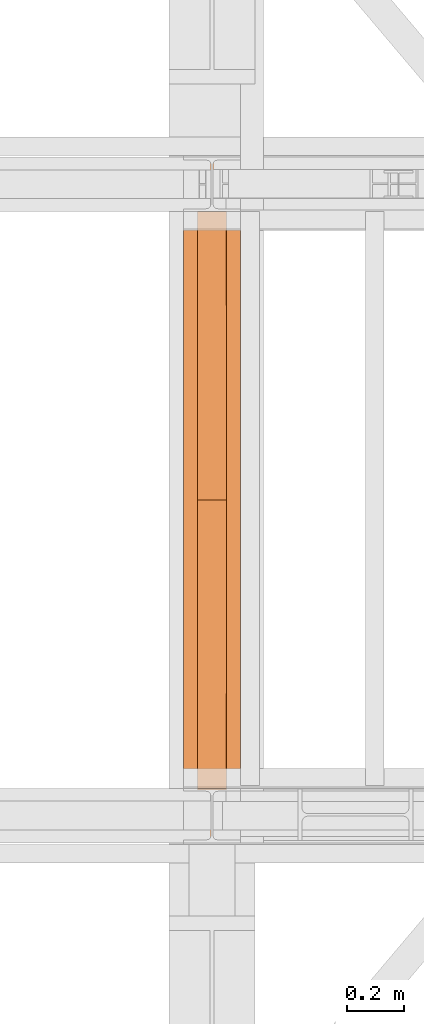
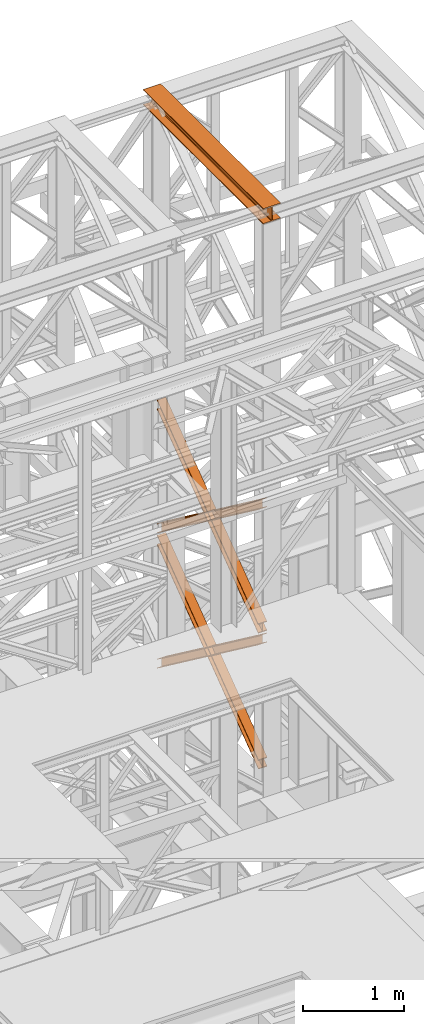
# One storey, part 167 of 208: 5 proxies.
"""IFC2X3 building model written with IfcOpenShell, lengths in millimetres."""

from ifc_helpers import new_model, entity, si_unit, converted_unit, frame, origin, origin_with_axes, place, context, subcontext, project, spatial, faceted_brep, element, save


model = new_model("IFC2X3")

# Units and contexts
model_context = context("Model", 3, precision=1e-05, world=origin())
plan_context = context("Plan", 3, precision=1e-05, world=origin())
body_context = subcontext(model_context, "Body", "Model", "MODEL_VIEW")
ifc_project = project(units=[si_unit("LENGTHUNIT", "METRE", prefix="MILLI"), converted_unit("PLANEANGLEUNIT", "DEGREE", entity("IfcPlaneAngleMeasure", 0.0174532925199433), si_unit("PLANEANGLEUNIT", "RADIAN"), dimensions=[0, 0, 0, 0, 0, 0, 0]), si_unit("AREAUNIT", "SQUARE_METRE"), si_unit("VOLUMEUNIT", "CUBIC_METRE")], contexts=[model_context, plan_context])

# Building, storey
building_placement = place(None, origin())
building = spatial("IfcBuilding", under=ifc_project, at=building_placement, CompositionType="COMPLEX")
storey_placement = place(building_placement, origin_with_axes())
storey = spatial("IfcBuildingStorey", under=building, at=storey_placement, Name="Geschoss", CompositionType="ELEMENT")

# Proxies
proxy_1_placement = place(storey_placement, frame((6493.25496703855, -16057.57439657638, 12249.99005869381), z_axis=(0.0, 0.0, 1.0), x_axis=(1.0, 0.0, 0.0)))
element("IfcBuildingElementProxy", 1, at=proxy_1_placement, inside=storey, context=body_context, shape_type="Brep", body=[
    faceted_brep([(0.01000000000021828, 2390.010012516977, 0.01000000000021828), (200.0100029802325, 2390.010012516977, 0.01000000000021828), (200.0100029802325, 2390.010012516977, 10.00999791383765), (121.2600035762789, 2390.010012516977, 10.01000536441825), (111.9441915473344, 2390.010012516977, 11.87455041170142), (105.1245498640838, 2390.010012516977, 18.69419349193595), (103.2600015571716, 2390.010012516977, 28.01000458955787), (103.2600015571716, 2390.010012516977, 162.0100153779986), (105.1245498640838, 2390.010012516977, 171.3258264756205), (111.9441915473344, 2390.010012516977, 178.145469555855), (121.2600035762789, 2390.010012516977, 180.0100146031382), (200.0100029802325, 2390.010012516977, 180.0100146031382), (200.0100029802325, 2390.010012516977, 190.0100125169756), (0.01000000000021828, 2390.010012516977, 190.0100125169756), (0.01000000000021828, 2390.010012516977, 180.0100146031382), (78.75999940395377, 2390.010012516977, 180.0100146031382), (88.07581143289826, 2390.010012516977, 178.145469555855), (94.89545311614893, 2390.010012516977, 171.3258264756205), (96.76000142306111, 2390.010012516977, 162.0100153779986), (96.76000142306111, 2390.010012516977, 28.01000458955787), (94.89545311614893, 2390.010012516977, 18.69419349193595), (88.07581143289826, 2390.010012516977, 11.87455041170142), (78.75999940395377, 2390.010012516977, 10.01000536441825), (0.01000000000021828, 2390.010012516977, 10.00999791383765), (200.0100029802325, 2390.010012516977, 0.01000000000021828), (0.01000000000021828, 2390.010012516977, 0.01000000000021828), (0.01000000000021828, 0.01000000000021828, 0.01000000000021828), (200.0100029802325, 0.01000000000021828, 0.01000000000021828), (200.0100029802325, 2390.010012516977, 10.00999791383765), (200.0100029802325, 2390.010012516977, 0.01000000000021828), (200.0100029802325, 0.01000000000021828, 0.01000000000021828), (200.0100029802325, 0.01000000000021828, 10.00999791383765), (121.2600035762789, 2390.010012516977, 10.01000536441825), (200.0100029802325, 2390.010012516977, 10.00999791383765), (200.0100029802325, 0.01000000000021828, 10.00999791383765), (121.2600035762789, 0.01000000000021828, 10.01000536441825), (111.9441915473344, 2390.010012516977, 11.87455041170142), (121.2600035762789, 2390.010012516977, 10.01000536441825), (121.2600035762789, 0.01000000000021828, 10.01000536441825), (111.9441915473344, 0.01000000000021828, 11.87455041170142), (105.1245498640838, 2390.010012516977, 18.69419349193595), (111.9441915473344, 2390.010012516977, 11.87455041170142), (111.9441915473344, 0.01000000000021828, 11.87455041170142), (105.1245498640838, 0.01000000000021828, 18.69419349193595), (103.2600015571716, 2390.010012516977, 28.01000458955787), (105.1245498640838, 2390.010012516977, 18.69419349193595), (105.1245498640838, 0.01000000000021828, 18.69419349193595), (103.2600015571716, 0.01000000000021828, 28.01000458955787), (103.2600015571716, 2390.010012516977, 162.0100153779986), (103.2600015571716, 2390.010012516977, 28.01000458955787), (103.2600015571716, 0.01000000000021828, 28.01000458955787), (103.2600015571716, 0.01000000000021828, 162.0100153779986), (105.1245498640838, 2390.010012516977, 171.3258264756205), (103.2600015571716, 2390.010012516977, 162.0100153779986), (103.2600015571716, 0.01000000000021828, 162.0100153779986), (105.1245498640838, 0.01000000000021828, 171.3258264756205), (111.9441915473344, 2390.010012516977, 178.145469555855), (105.1245498640838, 2390.010012516977, 171.3258264756205), (105.1245498640838, 0.01000000000021828, 171.3258264756205), (111.9441915473344, 0.01000000000021828, 178.145469555855), (121.2600035762789, 2390.010012516977, 180.0100146031382), (111.9441915473344, 2390.010012516977, 178.145469555855), (111.9441915473344, 0.01000000000021828, 178.145469555855), (121.2600035762789, 0.01000000000021828, 180.0100146031382), (200.0100029802325, 2390.010012516977, 180.0100146031382), (121.2600035762789, 2390.010012516977, 180.0100146031382), (121.2600035762789, 0.01000000000021828, 180.0100146031382), (200.0100029802325, 0.01000000000021828, 180.0100146031382), (200.0100029802325, 2390.010012516977, 190.0100125169756), (200.0100029802325, 2390.010012516977, 180.0100146031382), (200.0100029802325, 0.01000000000021828, 180.0100146031382), (200.0100029802325, 0.01000000000021828, 190.0100125169756), (0.01000000000021828, 2390.010012516977, 190.0100125169756), (200.0100029802325, 2390.010012516977, 190.0100125169756), (200.0100029802325, 0.01000000000021828, 190.0100125169756), (0.01000000000021828, 0.01000000000021828, 190.0100125169756), (0.01000000000021828, 2390.010012516977, 180.0100146031382), (0.01000000000021828, 2390.010012516977, 190.0100125169756), (0.01000000000021828, 0.01000000000021828, 190.0100125169756), (0.01000000000021828, 0.01000000000021828, 180.0100146031382), (78.75999940395377, 2390.010012516977, 180.0100146031382), (0.01000000000021828, 2390.010012516977, 180.0100146031382), (0.01000000000021828, 0.01000000000021828, 180.0100146031382), (78.75999940395377, 0.01000000000021828, 180.0100146031382), (88.07581143289826, 2390.010012516977, 178.145469555855), (78.75999940395377, 2390.010012516977, 180.0100146031382), (78.75999940395377, 0.01000000000021828, 180.0100146031382), (88.07581143289826, 0.01000000000021828, 178.145469555855), (94.89545311614893, 2390.010012516977, 171.3258264756205), (88.07581143289826, 2390.010012516977, 178.145469555855), (88.07581143289826, 0.01000000000021828, 178.145469555855), (94.89545311614893, 0.01000000000021828, 171.3258264756205), (96.76000142306111, 2390.010012516977, 162.0100153779986), (94.89545311614893, 2390.010012516977, 171.3258264756205), (94.89545311614893, 0.01000000000021828, 171.3258264756205), (96.76000142306111, 0.01000000000021828, 162.0100153779986), (96.76000142306111, 2390.010012516977, 28.01000458955787), (96.76000142306111, 2390.010012516977, 162.0100153779986), (96.76000142306111, 0.01000000000021828, 162.0100153779986), (96.76000142306111, 0.01000000000021828, 28.01000458955787), (94.89545311614893, 2390.010012516977, 18.69419349193595), (96.76000142306111, 2390.010012516977, 28.01000458955787), (96.76000142306111, 0.01000000000021828, 28.01000458955787), (94.89545311614893, 0.01000000000021828, 18.69419349193595), (88.07581143289826, 2390.010012516977, 11.87455041170142), (94.89545311614893, 2390.010012516977, 18.69419349193595), (94.89545311614893, 0.01000000000021828, 18.69419349193595), (88.07581143289826, 0.01000000000021828, 11.87455041170142), (78.75999940395377, 2390.010012516977, 10.01000536441825), (88.07581143289826, 2390.010012516977, 11.87455041170142), (88.07581143289826, 0.01000000000021828, 11.87455041170142), (78.75999940395377, 0.01000000000021828, 10.01000536441825), (0.01000000000021828, 2390.010012516977, 10.00999791383765), (78.75999940395377, 2390.010012516977, 10.01000536441825), (78.75999940395377, 0.01000000000021828, 10.01000536441825), (0.01000000000021828, 0.01000000000021828, 10.00999791383765), (0.01000000000021828, 2390.010012516977, 0.01000000000021828), (0.01000000000021828, 2390.010012516977, 10.00999791383765), (0.01000000000021828, 0.01000000000021828, 10.00999791383765), (0.01000000000021828, 0.01000000000021828, 0.01000000000021828), (0.01000000000021828, 0.01000000000021828, 0.01000000000021828), (0.01000000000021828, 0.01000000000021828, 10.00999791383765), (78.75999940395377, 0.01000000000021828, 10.01000536441825), (88.07581143289826, 0.01000000000021828, 11.87455041170142), (94.89545311614893, 0.01000000000021828, 18.69419349193595), (96.76000142306111, 0.01000000000021828, 28.01000458955787), (96.76000142306111, 0.01000000000021828, 162.0100153779986), (94.89545311614893, 0.01000000000021828, 171.3258264756205), (88.07581143289826, 0.01000000000021828, 178.145469555855), (78.75999940395377, 0.01000000000021828, 180.0100146031382), (0.01000000000021828, 0.01000000000021828, 180.0100146031382), (0.01000000000021828, 0.01000000000021828, 190.0100125169756), (200.0100029802325, 0.01000000000021828, 190.0100125169756), (200.0100029802325, 0.01000000000021828, 180.0100146031382), (121.2600035762789, 0.01000000000021828, 180.0100146031382), (111.9441915473344, 0.01000000000021828, 178.145469555855), (105.1245498640838, 0.01000000000021828, 171.3258264756205), (103.2600015571716, 0.01000000000021828, 162.0100153779986), (103.2600015571716, 0.01000000000021828, 28.01000458955787), (105.1245498640838, 0.01000000000021828, 18.69419349193595), (111.9441915473344, 0.01000000000021828, 11.87455041170142), (121.2600035762789, 0.01000000000021828, 10.01000536441825), (200.0100029802325, 0.01000000000021828, 10.00999791383765), (200.0100029802325, 0.01000000000021828, 0.01000000000021828)], [[[0, 1, 2, 3, 4, 5, 6, 7, 8, 9, 10, 11, 12, 13, 14, 15, 16, 17, 18, 19, 20, 21, 22, 23]], [[24, 25, 26, 27]], [[28, 29, 30, 31]], [[32, 33, 34, 35]], [[36, 37, 38, 39]], [[40, 41, 42, 43]], [[44, 45, 46, 47]], [[48, 49, 50, 51]], [[52, 53, 54, 55]], [[56, 57, 58, 59]], [[60, 61, 62, 63]], [[64, 65, 66, 67]], [[68, 69, 70, 71]], [[72, 73, 74, 75]], [[76, 77, 78, 79]], [[80, 81, 82, 83]], [[84, 85, 86, 87]], [[88, 89, 90, 91]], [[92, 93, 94, 95]], [[96, 97, 98, 99]], [[100, 101, 102, 103]], [[104, 105, 106, 107]], [[108, 109, 110, 111]], [[112, 113, 114, 115]], [[116, 117, 118, 119]], [[120, 121, 122, 123, 124, 125, 126, 127, 128, 129, 130, 131, 132, 133, 134, 135, 136, 137, 138, 139, 140, 141, 142, 143]]], orient=[[False], [False], [False], [False], [False], [False], [False], [False], [False], [False], [False], [False], [False], [False], [False], [False], [False], [False], [False], [False], [False], [False], [False], [False], [False], [False]]),
])
proxy_2_placement = place(storey_placement, frame((6543.082798491103, -15873.1965123697, 5499.689768811883), z_axis=(0.0, 0.0, 1.0), x_axis=(1.0, 0.0, 0.0)))
element("IfcBuildingElementProxy", 2, at=proxy_2_placement, inside=storey, context=body_context, shape_type="Brep", body=[
    faceted_brep([(100.0229428112289, 2015.632115793322, 1505.703241650141), (100.1858455764686, 1.953628280809426, 0.02100513656296243), (100.1847800613887, 1.791659257409265, 9.702984703128095), (100.0218641931642, 2015.632115793322, 1515.50632986583), (0.02294341679771605, 2015.632115793322, 1505.692236513578), (0.1858461820338562, 1.953628280809426, 0.01000000000021828), (100.1858455764686, 1.953628280809426, 0.02100513656296243), (100.0229428112289, 2015.632115793322, 1505.703241650141), (0.02186479873125791, 2015.632115793322, 1515.495324729271), (0.1847806669538841, 1.791659257407446, 9.691979566568989), (0.1858461820338562, 1.953628280809426, 0.01000000000021828), (0.02294341679771605, 2015.632115793322, 1505.692236513578), (47.52186451108355, 2015.632115793322, 1515.500552169136), (47.68478037930981, 1.791659257407446, 9.697207006434837), (0.1847806669538841, 1.791659257407446, 9.691979566568989), (0.02186479873125791, 2015.632115793322, 1515.495324729271), (47.51107833042624, 2015.632115793322, 1613.531434326045), (47.67412522851737, 0.1719690234003792, 106.517002672068), (47.68478037930981, 1.791659257407446, 9.697207006434837), (47.52186451108355, 2015.632115793322, 1515.500552169136), (0.01107861806849542, 2015.632115793322, 1613.526206886179), (0.174125516157801, 0.1719690234003792, 106.5117752322021), (47.67412522851737, 0.1719690234003792, 106.517002672068), (47.51107833042624, 2015.632115793322, 1613.531434326045), (0.01000000000021828, 2015.632115793322, 1623.329295101868), (0.1730600010778289, 0.01000000000021828, 116.1937547987636), (0.174125516157801, 0.1719690234003792, 106.5117752322021), (0.01107861806849542, 2015.632115793322, 1613.526206886179), (100.0099993944386, 2015.632115793322, 1623.340300238435), (100.1730593955126, 0.01000000000203727, 116.2047599353264), (0.1730600010778289, 0.01000000000021828, 116.1937547987636), (0.01000000000021828, 2015.632115793322, 1623.329295101868), (100.0110780125051, 2015.632115793322, 1613.537212022739), (100.1741249105908, 0.1719690234003792, 106.5227803687612), (100.1730593955126, 0.01000000000203727, 116.2047599353264), (100.0099993944386, 2015.632115793322, 1623.340300238435), (52.51107830014917, 2015.632115793322, 1613.531984582873), (52.67412519823665, 0.1719690234003792, 106.5175529288954), (100.1741249105908, 0.1719690234003792, 106.5227803687612), (100.0110780125051, 2015.632115793322, 1613.537212022739), (52.52186448080829, 2015.632115793322, 1515.501102425964), (52.68478034903274, 1.791659257409265, 9.697757263262247), (52.67412519823665, 0.1719690234003792, 106.5175529288954), (52.51107830014917, 2015.632115793322, 1613.531984582873), (100.0218641931642, 2015.632115793322, 1515.50632986583), (100.1847800613887, 1.791659257409265, 9.702984703128095), (52.68478034903274, 1.791659257409265, 9.697757263262247), (52.52186448080829, 2015.632115793322, 1515.501102425964), (100.1858455764686, 1.953628280809426, 0.02100513656296243), (0.1858461820338562, 1.953628280809426, 0.01000000000021828), (0.1847806669538841, 1.791659257407446, 9.691979566568989), (47.68478037930981, 1.791659257407446, 9.697207006434837), (47.67412522851737, 0.1719690234003792, 106.517002672068), (0.174125516157801, 0.1719690234003792, 106.5117752322021), (0.1730600010778289, 0.01000000000021828, 116.1937547987636), (100.1730593955126, 0.01000000000203727, 116.2047599353264), (100.1741249105908, 0.1719690234003792, 106.5227803687612), (52.67412519823665, 0.1719690234003792, 106.5175529288954), (52.68478034903274, 1.791659257409265, 9.697757263262247), (100.1847800613887, 1.791659257409265, 9.702984703128095), (100.0218641931642, 2015.632115793322, 1515.50632986583), (52.52186448080829, 2015.632115793322, 1515.501102425964), (52.51107830014917, 2015.632115793322, 1613.531984582873), (100.0110780125051, 2015.632115793322, 1613.537212022739), (100.0099993944386, 2015.632115793322, 1623.340300238435), (0.01000000000021828, 2015.632115793322, 1623.329295101868), (0.01107861806849542, 2015.632115793322, 1613.526206886179), (47.51107833042624, 2015.632115793322, 1613.531434326045), (47.52186451108355, 2015.632115793322, 1515.500552169136), (0.02186479873125791, 2015.632115793322, 1515.495324729271), (0.02294341679771605, 2015.632115793322, 1505.692236513578), (100.0229428112289, 2015.632115793322, 1505.703241650141)], [[[0, 1, 2, 3]], [[4, 5, 6, 7]], [[8, 9, 10, 11]], [[12, 13, 14, 15]], [[16, 17, 18, 19]], [[20, 21, 22, 23]], [[24, 25, 26, 27]], [[28, 29, 30, 31]], [[32, 33, 34, 35]], [[36, 37, 38, 39]], [[40, 41, 42, 43]], [[44, 45, 46, 47]], [[48, 49, 50, 51, 52, 53, 54, 55, 56, 57, 58, 59]], [[60, 61, 62, 63, 64, 65, 66, 67, 68, 69, 70, 71]]], orient=[[False], [False], [False], [False], [False], [False], [False], [False], [False], [False], [False], [False], [False], [False]]),
])
proxy_3_placement = place(storey_placement, frame((6543.082676642578, -15867.5743840594, 5504.219540188055), z_axis=(0.0, 0.0, 1.0), x_axis=(1.0, 0.0, 0.0)))
element("IfcBuildingElementProxy", 3, at=proxy_3_placement, inside=storey, context=body_context, shape_type="Brep", body=[
    faceted_brep([(100.0218596475406, 0.01000000000021828, 1511.076608371926), (100.1844513161013, 2010.009987483025, 9.820176864343011), (100.1855295209298, 2010.009987483025, 0.02100513655932446), (100.0229378523673, 0.01000000000021828, 1501.277436644132), (100.0229378523673, 0.01000000000021828, 1501.277436644132), (100.1855295209298, 2010.009987483025, 0.02100513655932446), (0.1855301264913578, 2010.009987483025, 0.01000000000021828), (0.02293845793246874, 0.01000000000021828, 1501.266431507576), (0.02293845793246874, 0.01000000000021828, 1501.266431507576), (0.1855301264913578, 2010.009987483025, 0.01000000000021828), (0.1844519216665503, 2010.009987483025, 9.809171727787543), (0.02186025310402329, 0.01000000000021828, 1511.06560323536), (0.02186025310402329, 0.01000000000021828, 1511.06560323536), (0.1844519216665503, 2010.009987483025, 9.809171727787543), (47.6844516340243, 2010.009987483025, 9.814399167646116), (47.52185996546359, 0.01000000000021828, 1511.070830675226), (47.52185996546359, 0.01000000000021828, 1511.070830675226), (47.6844516340243, 2010.009987483025, 9.814399167646116), (47.6736695857453, 2010.009987483025, 107.8061164454975), (47.51107791718459, 0.01000000000021828, 1609.062547953077), (47.51107791718459, 0.01000000000021828, 1609.062547953077), (47.6736695857453, 2010.009987483025, 107.8061164454975), (0.1736698733893718, 2010.009987483025, 107.8008890056317), (0.01107820482866373, 0.01000000000021828, 1609.057320513211), (0.01107820482866373, 0.01000000000021828, 1609.057320513211), (0.1736698733893718, 2010.009987483025, 107.8008890056317), (0.1725916685609263, 2010.009987483025, 117.6000607334227), (0.01000000000021828, 0.01000000000021828, 1618.856492240995), (0.01000000000021828, 0.01000000000021828, 1618.856492240995), (0.1725916685609263, 2010.009987483025, 117.6000607334227), (100.1725910629975, 2010.009987483025, 117.6110658699781), (100.009999394435, 0.01000000000021828, 1618.867497377558), (100.009999394435, 0.01000000000021828, 1618.867497377558), (100.1725910629975, 2010.009987483025, 117.6110658699781), (100.1736692678242, 2010.009987483025, 107.8118941421981), (100.0110775992634, 0.01000000000021828, 1609.068325649774), (100.0110775992634, 0.01000000000021828, 1609.068325649774), (100.1736692678242, 2010.009987483025, 107.8118941421981), (52.67366955546459, 2010.009987483025, 107.806666702325), (52.51107788690388, 0.01000000000021828, 1609.063098209905), (52.51107788690388, 0.01000000000021828, 1609.063098209905), (52.67366955546459, 2010.009987483025, 107.806666702325), (52.6844516037454, 2010.009987483025, 9.814949424477163), (52.52185993518287, 0.01000000000021828, 1511.071380932057), (52.52185993518287, 0.01000000000021828, 1511.071380932057), (52.6844516037454, 2010.009987483025, 9.814949424477163), (100.1844513161013, 2010.009987483025, 9.820176864343011), (100.0218596475406, 0.01000000000021828, 1511.076608371926), (100.1844513161013, 2010.009987483025, 9.820176864343011), (52.6844516037454, 2010.009987483025, 9.814949424477163), (52.67366955546459, 2010.009987483025, 107.806666702325), (100.1736692678242, 2010.009987483025, 107.8118941421981), (100.1725910629975, 2010.009987483025, 117.6110658699781), (0.1725916685609263, 2010.009987483025, 117.6000607334227), (0.1736698733893718, 2010.009987483025, 107.8008890056317), (47.6736695857453, 2010.009987483025, 107.8061164454975), (47.6844516340243, 2010.009987483025, 9.814399167646116), (0.1844519216665503, 2010.009987483025, 9.809171727787543), (0.1855301264913578, 2010.009987483025, 0.01000000000021828), (100.1855295209298, 2010.009987483025, 0.02100513655932446), (100.0229378523673, 0.01000000000021828, 1501.277436644132), (0.02293845793246874, 0.01000000000021828, 1501.266431507576), (0.02186025310402329, 0.01000000000021828, 1511.06560323536), (47.52185996546359, 0.01000000000021828, 1511.070830675226), (47.51107791718459, 0.01000000000021828, 1609.062547953077), (0.01107820482866373, 0.01000000000021828, 1609.057320513211), (0.01000000000021828, 0.01000000000021828, 1618.856492240995), (100.009999394435, 0.01000000000021828, 1618.867497377558), (100.0110775992634, 0.01000000000021828, 1609.068325649774), (52.51107788690388, 0.01000000000021828, 1609.063098209905), (52.52185993518287, 0.01000000000021828, 1511.071380932057), (100.0218596475406, 0.01000000000021828, 1511.076608371926)], [[[0, 1, 2, 3]], [[4, 5, 6, 7]], [[8, 9, 10, 11]], [[12, 13, 14, 15]], [[16, 17, 18, 19]], [[20, 21, 22, 23]], [[24, 25, 26, 27]], [[28, 29, 30, 31]], [[32, 33, 34, 35]], [[36, 37, 38, 39]], [[40, 41, 42, 43]], [[44, 45, 46, 47]], [[48, 49, 50, 51, 52, 53, 54, 55, 56, 57, 58, 59]], [[60, 61, 62, 63, 64, 65, 66, 67, 68, 69, 70, 71]]], orient=[[False], [False], [False], [False], [False], [False], [False], [False], [False], [False], [False], [False], [False], [False]]),
])
proxy_4_placement = place(storey_placement, frame((6542.895475356376, -15867.5743840594, 7147.441290649187), z_axis=(0.0, 0.0, 1.0), x_axis=(1.0, 0.0, 0.0)))
element("IfcBuildingElementProxy", 4, at=proxy_4_placement, inside=storey, context=body_context, shape_type="Brep", body=[
    faceted_brep([(100.0218623025612, 0.01000000000021828, 1512.063556389601), (100.1844166626906, 2010.009987483025, 9.822513400360549), (100.1854951088862, 2010.009987483025, 0.02100513655932446), (100.022940748755, 0.01000000000021828, 1502.262048125804), (100.022940748755, 0.01000000000021828, 1502.262048125804), (100.1854951088862, 2010.009987483025, 0.02100513655932446), (0.1854957144514629, 2010.009987483025, 0.01000000000021828), (0.02294135431839095, 0.01000000000021828, 1502.251042989237), (0.02294135431839095, 0.01000000000021828, 1502.251042989237), (0.1854957144514629, 2010.009987483025, 0.01000000000021828), (0.1844172682558565, 2010.009987483025, 9.811508263797805), (0.02186290812642255, 0.01000000000021828, 1512.052551253039), (0.02186290812642255, 0.01000000000021828, 1512.052551253039), (0.1844172682558565, 2010.009987483025, 9.811508263797805), (47.68441698061361, 2010.009987483025, 9.816735703663653), (47.52186262048235, 0.01000000000021828, 1512.057778692908), (47.52186262048235, 0.01000000000021828, 1512.057778692908), (47.68441698061361, 2010.009987483025, 9.816735703663653), (47.67363251868483, 2010.009987483025, 107.8318183416577), (47.51107815855175, 0.01000000000021828, 1610.072861330906), (47.51107815855175, 0.01000000000021828, 1610.072861330906), (47.67363251868483, 2010.009987483025, 107.8318183416577), (0.1736328063252586, 2010.009987483025, 107.8265909017955), (0.01107844619582465, 0.01000000000021828, 1610.067633891033), (0.01107844619582465, 0.01000000000021828, 1610.067633891033), (0.1736328063252586, 2010.009987483025, 107.8265909017955), (0.1725543601314712, 2010.009987483025, 117.6280991655931), (0.01000000000021828, 0.01000000000021828, 1619.86914215483), (0.01000000000021828, 0.01000000000021828, 1619.86914215483), (0.1725543601314712, 2010.009987483025, 117.6280991655931), (100.1725537545663, 2010.009987483025, 117.6391043021558), (100.009999394435, 0.01000000000021828, 1619.880147291397), (100.009999394435, 0.01000000000021828, 1619.880147291397), (100.1725537545663, 2010.009987483025, 117.6391043021558), (100.1736322007619, 2010.009987483025, 107.8375960383546), (100.0110778406306, 0.01000000000021828, 1610.078639027603), (100.0110778406306, 0.01000000000021828, 1610.078639027603), (100.1736322007619, 2010.009987483025, 107.8375960383546), (52.67363248840411, 2010.009987483025, 107.8323685984888), (52.51107812827468, 0.01000000000021828, 1610.073411587733), (52.51107812827468, 0.01000000000021828, 1610.073411587733), (52.67363248840411, 2010.009987483025, 107.8323685984888), (52.68441695033471, 2010.009987483025, 9.817285960491063), (52.52186259020346, 0.01000000000021828, 1512.058328949732), (52.52186259020346, 0.01000000000021828, 1512.058328949732), (52.68441695033471, 2010.009987483025, 9.817285960491063), (100.1844166626906, 2010.009987483025, 9.822513400360549), (100.0218623025612, 0.01000000000021828, 1512.063556389601), (100.1844166626906, 2010.009987483025, 9.822513400360549), (52.68441695033471, 2010.009987483025, 9.817285960491063), (52.67363248840411, 2010.009987483025, 107.8323685984888), (100.1736322007619, 2010.009987483025, 107.8375960383546), (100.1725537545663, 2010.009987483025, 117.6391043021558), (0.1725543601314712, 2010.009987483025, 117.6280991655931), (0.1736328063252586, 2010.009987483025, 107.8265909017955), (47.67363251868483, 2010.009987483025, 107.8318183416577), (47.68441698061361, 2010.009987483025, 9.816735703663653), (0.1844172682558565, 2010.009987483025, 9.811508263797805), (0.1854957144514629, 2010.009987483025, 0.01000000000021828), (100.1854951088862, 2010.009987483025, 0.02100513655932446), (100.022940748755, 0.01000000000021828, 1502.262048125804), (0.02294135431839095, 0.01000000000021828, 1502.251042989237), (0.02186290812642255, 0.01000000000021828, 1512.052551253039), (47.52186262048235, 0.01000000000021828, 1512.057778692908), (47.51107815855175, 0.01000000000021828, 1610.072861330906), (0.01107844619582465, 0.01000000000021828, 1610.067633891033), (0.01000000000021828, 0.01000000000021828, 1619.86914215483), (100.009999394435, 0.01000000000021828, 1619.880147291397), (100.0110778406306, 0.01000000000021828, 1610.078639027603), (52.51107812827468, 0.01000000000021828, 1610.073411587733), (52.52186259020346, 0.01000000000021828, 1512.058328949732), (100.0218623025612, 0.01000000000021828, 1512.063556389601)], [[[0, 1, 2, 3]], [[4, 5, 6, 7]], [[8, 9, 10, 11]], [[12, 13, 14, 15]], [[16, 17, 18, 19]], [[20, 21, 22, 23]], [[24, 25, 26, 27]], [[28, 29, 30, 31]], [[32, 33, 34, 35]], [[36, 37, 38, 39]], [[40, 41, 42, 43]], [[44, 45, 46, 47]], [[48, 49, 50, 51, 52, 53, 54, 55, 56, 57, 58, 59]], [[60, 61, 62, 63, 64, 65, 66, 67, 68, 69, 70, 71]]], orient=[[False], [False], [False], [False], [False], [False], [False], [False], [False], [False], [False], [False], [False], [False]]),
])
proxy_5_placement = place(storey_placement, frame((6542.895647595429, -15867.5743840594, 7147.394064575148), z_axis=(0.0, 0.0, 1.0), x_axis=(1.0, 0.0, 0.0)))
element("IfcBuildingElementProxy", 5, at=proxy_5_placement, inside=storey, context=body_context, shape_type="Brep", body=[
    faceted_brep([(100.0229386519513, 2010.009987483025, 1501.524522111415), (100.185572907496, 0.01000000000021828, 0.02100513656296243), (100.1844946360361, 0.01000000000021828, 9.82075546136366), (100.0218603804915, 2010.009987483025, 1511.324272436212), (0.02293925751655479, 2010.009987483025, 1501.513516974852), (0.185573513059353, 0.01000000000021828, 0.01000000000021828), (100.185572907496, 0.01000000000021828, 0.02100513656296243), (100.0229386519513, 2010.009987483025, 1501.524522111415), (0.02186098605488951, 2010.009987483025, 1511.313267299649), (0.1844952415995067, 0.01000000000021828, 9.809750324800916), (0.185573513059353, 0.01000000000021828, 0.01000000000021828), (0.02293925751655479, 2010.009987483025, 1501.513516974852), (47.52186069841264, 2010.009987483025, 1511.318494739518), (47.68449495395544, 0.01000000000021828, 9.814977764666764), (0.1844952415995067, 0.01000000000021828, 9.809750324800916), (0.02186098605488951, 2010.009987483025, 1511.313267299649), (47.51107798381418, 2010.009987483025, 1609.315997987507), (47.67371223936061, 0.01000000000021828, 107.8124810126556), (47.68449495395544, 0.01000000000021828, 9.814977764666764), (47.52186069841264, 2010.009987483025, 1511.318494739518), (0.01107827146006457, 2010.009987483025, 1609.310770547641), (0.1737125270028628, 0.01000000000021828, 107.8072535727861), (47.67371223936061, 0.01000000000021828, 107.8124810126556), (47.51107798381418, 2010.009987483025, 1609.315997987507), (0.01000000000021828, 2010.009987483025, 1619.110520872438), (0.1726342555448355, 0.01000000000021828, 117.6070038975868), (0.1737125270028628, 0.01000000000021828, 107.8072535727861), (0.01107827146006457, 2010.009987483025, 1609.310770547641), (100.009999394435, 2010.009987483025, 1619.121526009001), (100.1726336499778, 0.01000000000021828, 117.6180090341495), (0.1726342555448355, 0.01000000000021828, 117.6070038975868), (0.01000000000021828, 2010.009987483025, 1619.110520872438), (100.0110776658949, 2010.009987483025, 1609.321775684197), (100.1737119214376, 0.01000000000021828, 107.8182587093452), (100.1726336499778, 0.01000000000021828, 117.6180090341495), (100.009999394435, 2010.009987483025, 1619.121526009001), (52.5110779535371, 2010.009987483025, 1609.316548244331), (52.67371220908353, 0.01000000000021828, 107.8130312694793), (100.1737119214376, 0.01000000000021828, 107.8182587093452), (100.0110776658949, 2010.009987483025, 1609.321775684197), (52.52186066813374, 2010.009987483025, 1511.319044996339), (52.68449492368018, 0.01000000000021828, 9.815528021497812), (52.67371220908353, 0.01000000000021828, 107.8130312694793), (52.5110779535371, 2010.009987483025, 1609.316548244331), (100.0218603804915, 2010.009987483025, 1511.324272436212), (100.1844946360361, 0.01000000000021828, 9.82075546136366), (52.68449492368018, 0.01000000000021828, 9.815528021497812), (52.52186066813374, 2010.009987483025, 1511.319044996339), (100.185572907496, 0.01000000000021828, 0.02100513656296243), (0.185573513059353, 0.01000000000021828, 0.01000000000021828), (0.1844952415995067, 0.01000000000021828, 9.809750324800916), (47.68449495395544, 0.01000000000021828, 9.814977764666764), (47.67371223936061, 0.01000000000021828, 107.8124810126556), (0.1737125270028628, 0.01000000000021828, 107.8072535727861), (0.1726342555448355, 0.01000000000021828, 117.6070038975868), (100.1726336499778, 0.01000000000021828, 117.6180090341495), (100.1737119214376, 0.01000000000021828, 107.8182587093452), (52.67371220908353, 0.01000000000021828, 107.8130312694793), (52.68449492368018, 0.01000000000021828, 9.815528021497812), (100.1844946360361, 0.01000000000021828, 9.82075546136366), (100.0218603804915, 2010.009987483025, 1511.324272436212), (52.52186066813374, 2010.009987483025, 1511.319044996339), (52.5110779535371, 2010.009987483025, 1609.316548244331), (100.0110776658949, 2010.009987483025, 1609.321775684197), (100.009999394435, 2010.009987483025, 1619.121526009001), (0.01000000000021828, 2010.009987483025, 1619.110520872438), (0.01107827146006457, 2010.009987483025, 1609.310770547641), (47.51107798381418, 2010.009987483025, 1609.315997987507), (47.52186069841264, 2010.009987483025, 1511.318494739518), (0.02186098605488951, 2010.009987483025, 1511.313267299649), (0.02293925751655479, 2010.009987483025, 1501.513516974852), (100.0229386519513, 2010.009987483025, 1501.524522111415)], [[[0, 1, 2, 3]], [[4, 5, 6, 7]], [[8, 9, 10, 11]], [[12, 13, 14, 15]], [[16, 17, 18, 19]], [[20, 21, 22, 23]], [[24, 25, 26, 27]], [[28, 29, 30, 31]], [[32, 33, 34, 35]], [[36, 37, 38, 39]], [[40, 41, 42, 43]], [[44, 45, 46, 47]], [[48, 49, 50, 51, 52, 53, 54, 55, 56, 57, 58, 59]], [[60, 61, 62, 63, 64, 65, 66, 67, 68, 69, 70, 71]]], orient=[[False], [False], [False], [False], [False], [False], [False], [False], [False], [False], [False], [False], [False], [False]]),
])

save(model, "model.ifc")
